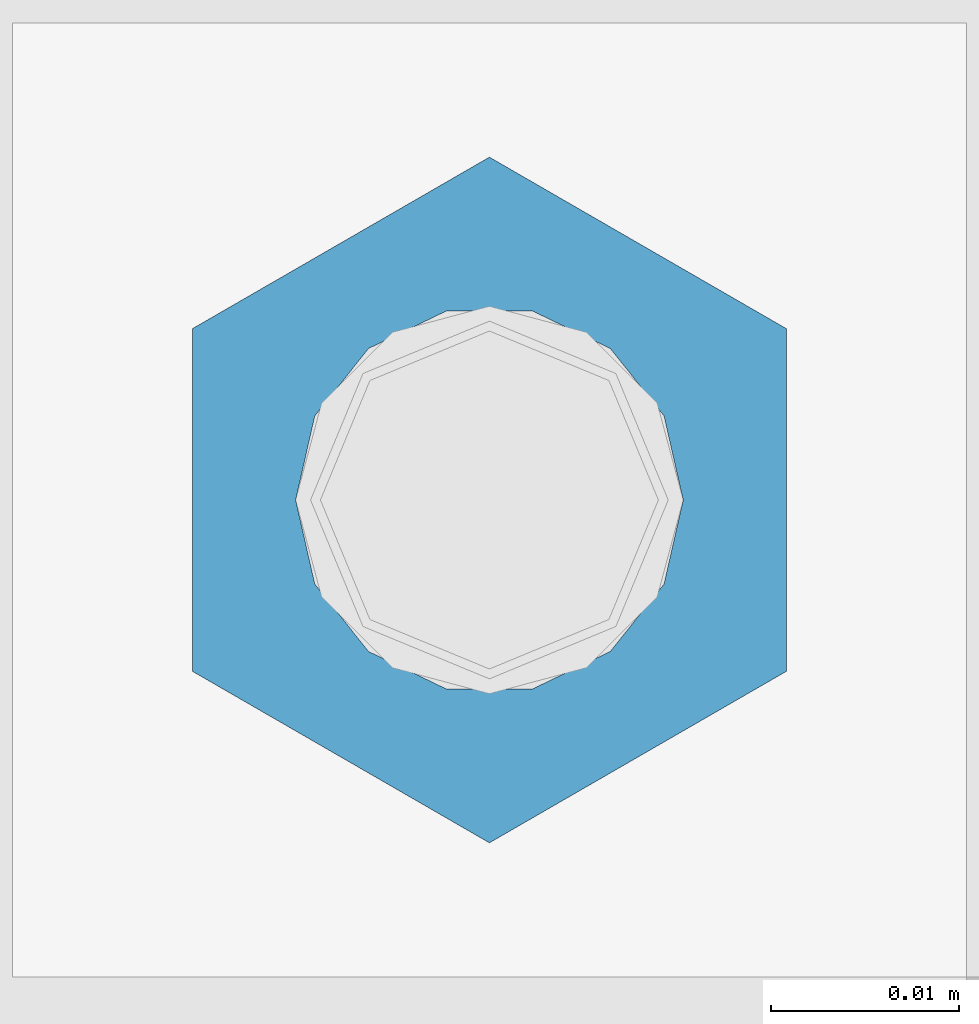
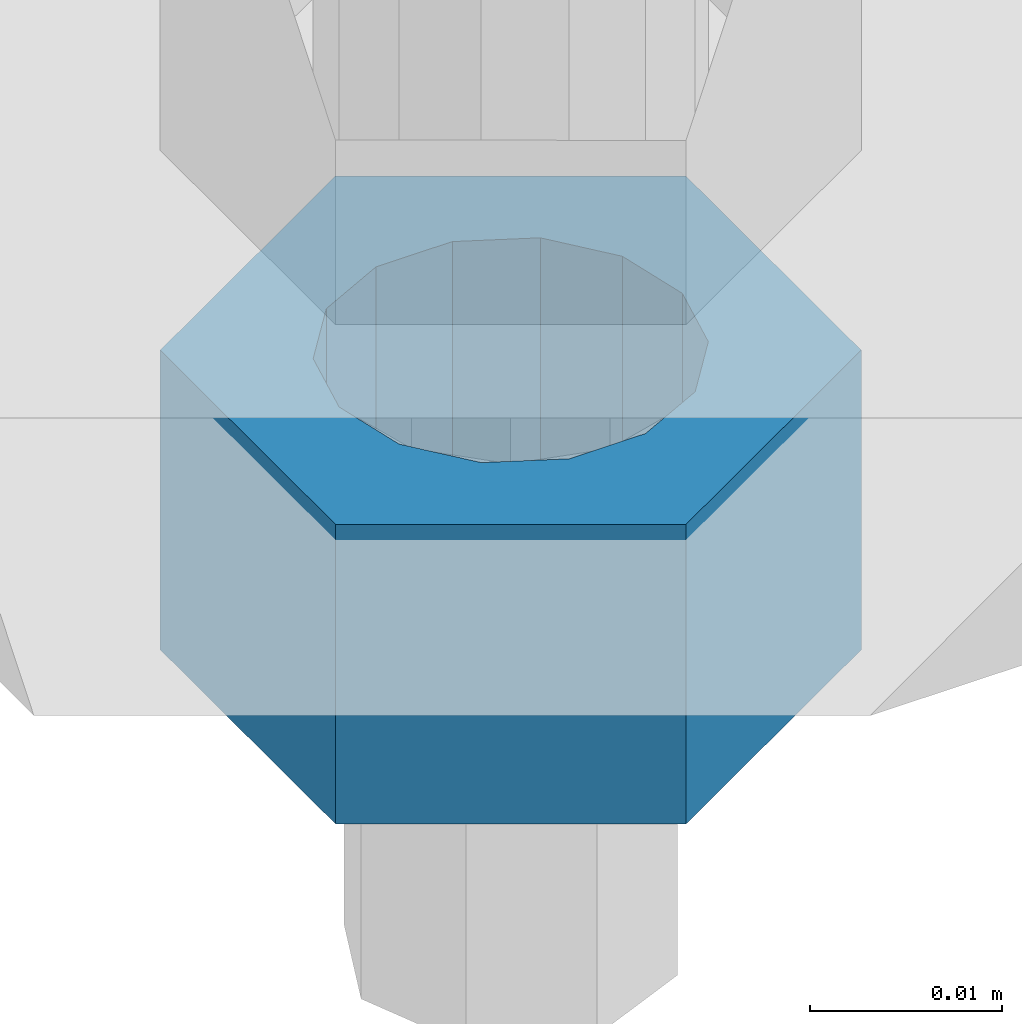
# One storey, part 1691 of 3843: 1 column, 1 element without a shape of its own.
"""IFC2X3 building model written with IfcOpenShell, lengths in millimetres."""

from ifc_helpers import new_model, si_unit, frame, origin_with_axes, place, context, subcontext, project, spatial, faceted_brep, material, type_object, element, aggregate, save


model = new_model("IFC2X3")

# Units and contexts
model_context = context("Model", 3, precision=1e-05, world=origin_with_axes())
body_context = subcontext(model_context, "Body", "Model", "MODEL_VIEW")
ifc_project = project(units=[si_unit("LENGTHUNIT", "METRE", prefix="MILLI"), si_unit("AREAUNIT", "SQUARE_METRE"), si_unit("VOLUMEUNIT", "CUBIC_METRE"), si_unit("MASSUNIT", "GRAM", prefix="KILO"), si_unit("TIMEUNIT", "SECOND"), si_unit("PLANEANGLEUNIT", "RADIAN"), si_unit("SOLIDANGLEUNIT", "STERADIAN"), si_unit("THERMODYNAMICTEMPERATUREUNIT", "DEGREE_CELSIUS"), si_unit("LUMINOUSINTENSITYUNIT", "LUMEN")], contexts=[model_context])

# Site, building, storey
site_placement = place(None, origin_with_axes())
site = spatial("IfcSite", under=ifc_project, at=site_placement, CompositionType="ELEMENT")
building_placement = place(site_placement, origin_with_axes())
building = spatial("IfcBuilding", under=site, at=building_placement, Name="Undefined", CompositionType="ELEMENT")
storey_placement = place(building_placement, origin_with_axes())
storey = spatial("IfcBuildingStorey", under=building, at=storey_placement, Name="Undefined", CompositionType="ELEMENT", Elevation=0.0)

# Assembly, column
assembly_placement = place(storey_placement, origin_with_axes())
assembly = element("IfcElementAssembly", 1, at=assembly_placement, inside=storey, Name="TEMPLATE", AssemblyPlace="NOTDEFINED", PredefinedType="RIGID_FRAME")
ifc_material = material(Name="STEEL/A36")
column_type = type_object("IfcColumnType", Name="3/4_HEAVY_HEX_NUT", PredefinedType="NOTDEFINED")
column_placement = place(assembly_placement, frame((38744.525, 67348.1, 29756.1), z_axis=(-1.0, 0.0, 0.0), x_axis=(0.0, 0.0, -1.0)))
column = element("IfcColumn", 2, at=column_placement, type_object=column_type, material=ifc_material, Name="NUT", ObjectType="3/4_HEAVY_HEX_NUT", context=body_context, shape_type="Brep", body=[
    faceted_brep([(0.0, -18.2600002288818, 0.0), (0.0, -9.13000011444092, -15.8100004196167), (19.0500000000029, -9.13000011444092, -15.8100004196167), (19.0500000000029, -18.2600002288818, 0.0), (0.0, 9.13000011444092, -15.8100004196167), (19.0500000000029, 9.13000011444092, -15.8100004196167), (0.0, 18.2600002288818, 0.0), (19.0500000000029, 18.2600002288818, 0.0), (0.0, 9.13000011444092, 15.8100004196167), (19.0500000000029, 9.13000011444092, 15.8100004196167), (0.0, -9.13000011444092, 15.8100004196167), (19.0500000000029, -9.13000011444092, 15.8100004196167), (0.0, 0.0, 10.3199996948242), (0.0, 4.47768005527905, 9.29799844179797), (19.0500000000029, 4.47768005527905, 9.29799844179797), (19.0500000000029, 0.0, 10.3199996948242), (0.0, 8.06850066047627, 6.43441456490837), (19.0500000000029, 8.06850066047627, 6.43441456490837), (0.0, 10.0612557561908, 2.2964159705225), (19.0500000000029, 10.0612557561908, 2.2964159705225), (0.0, 10.0612557561908, -2.2964159705225), (19.0500000000029, 10.0612557561908, -2.2964159705225), (0.0, 8.06850066047627, -6.43441456490837), (19.0500000000029, 8.06850066047627, -6.43441456490837), (0.0, 4.47768005527905, -9.29799844179797), (19.0500000000029, 4.47768005527905, -9.29799844179797), (0.0, 0.0, -10.3199996948242), (19.0500000000029, 0.0, -10.3199996948242), (0.0, -4.47768005527905, -9.29799844179797), (19.0500000000029, -4.47768005527905, -9.29799844179797), (0.0, -8.06850066047627, -6.43441456490837), (19.0500000000029, -8.06850066047627, -6.43441456490837), (0.0, -10.0612557561908, -2.2964159705225), (19.0500000000029, -10.0612557561908, -2.2964159705225), (0.0, -10.0612557561908, 2.2964159705225), (19.0500000000029, -10.0612557561908, 2.2964159705225), (0.0, -8.06850066047627, 6.43441456490837), (19.0500000000029, -8.06850066047627, 6.43441456490837), (0.0, -4.47768005527905, 9.29799844179797), (19.0500000000029, -4.47768005527905, 9.29799844179797)], [[[0, 1, 2, 3]], [[1, 4, 5, 2]], [[4, 6, 7, 5]], [[6, 8, 9, 7]], [[8, 10, 11, 9]], [[10, 0, 3, 11]], [[12, 13, 14, 15]], [[13, 16, 17, 14]], [[16, 18, 19, 17]], [[18, 20, 21, 19]], [[20, 22, 23, 21]], [[22, 24, 25, 23]], [[24, 26, 27, 25]], [[26, 28, 29, 27]], [[28, 30, 31, 29]], [[30, 32, 33, 31]], [[32, 34, 35, 33]], [[34, 36, 37, 35]], [[36, 38, 39, 37]], [[38, 12, 15, 39]], [[5, 7, 9, 11, 3, 2], [17, 19, 21, 23, 25, 27, 29, 31, 33, 35, 37, 39, 15, 14]], [[10, 8, 6, 4, 1, 0], [38, 36, 34, 32, 30, 28, 26, 24, 22, 20, 18, 16, 13, 12]]]),
])
aggregate(assembly, [column])

save(model, "model.ifc")
